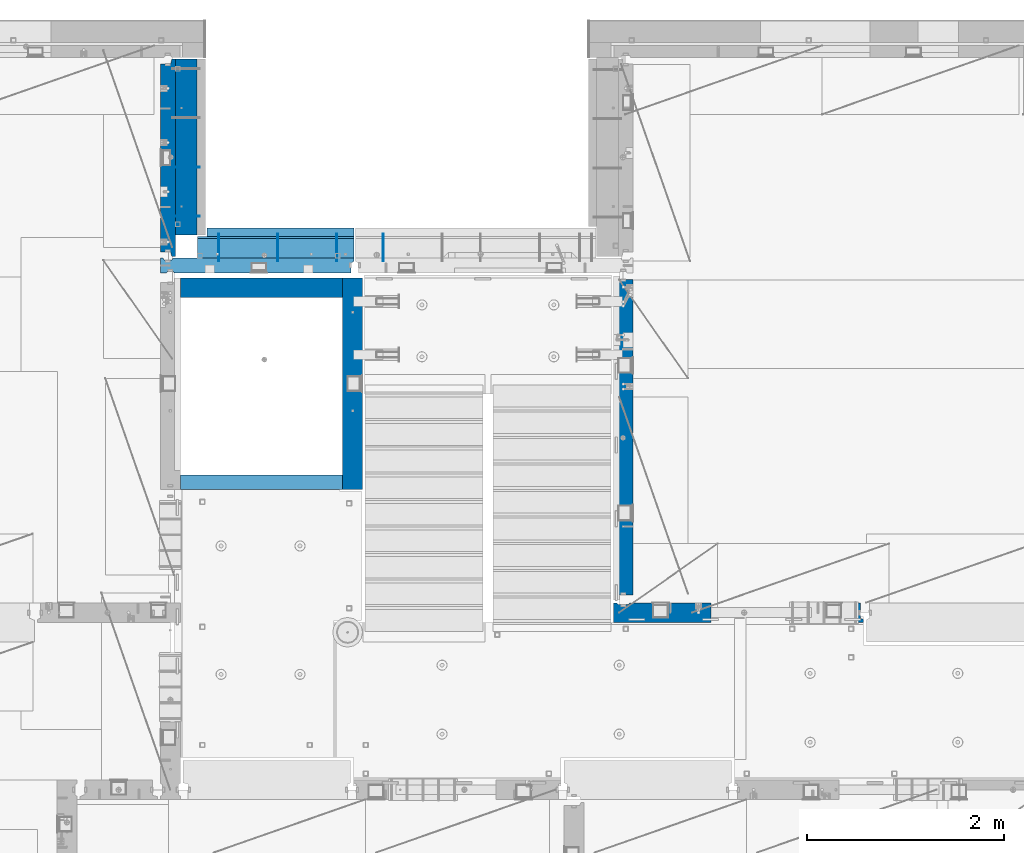
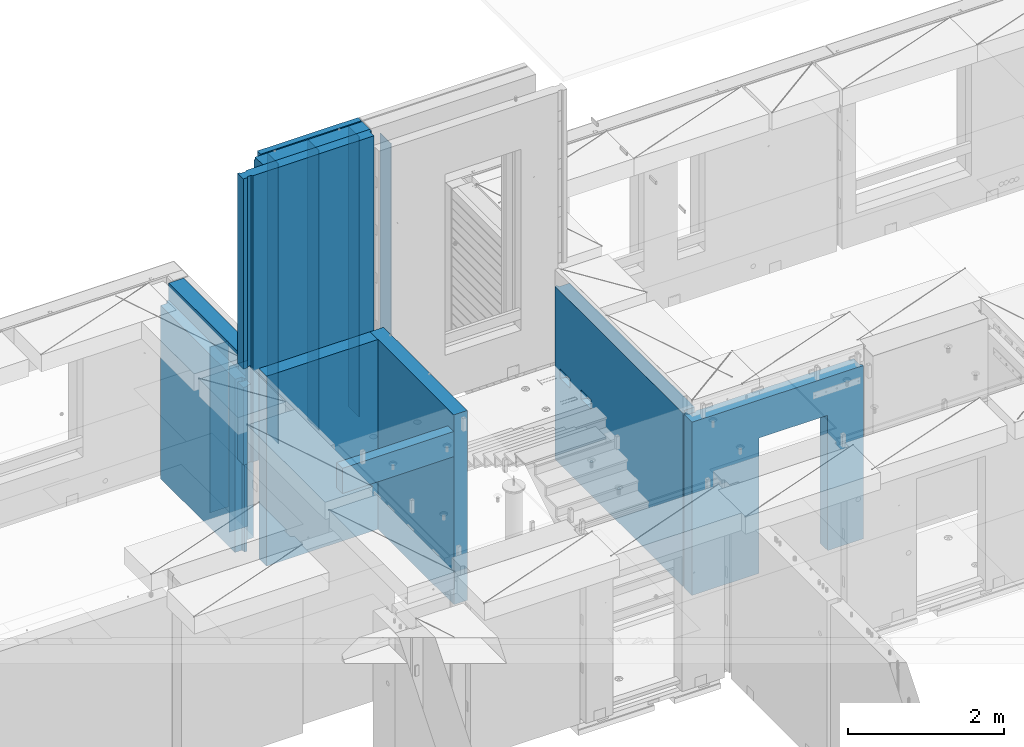
# One storey, part 238 of 352: 16 walls, 7 elements without a shape of their own.
"""IFC2X3 building model written with IfcOpenShell, lengths in millimetres."""

from ifc_helpers import new_model, si_unit, frame, origin_with_axes, place, context, subcontext, project, spatial, faceted_brep, material, type_object, element, aggregate, save


model = new_model("IFC2X3")

# Units and contexts
model_context = context("Model", 3, precision=1e-05, world=origin_with_axes())
body_context = subcontext(model_context, "Body", "Model", "MODEL_VIEW")
ifc_project = project(units=[si_unit("LENGTHUNIT", "METRE", prefix="MILLI"), si_unit("AREAUNIT", "SQUARE_METRE"), si_unit("VOLUMEUNIT", "CUBIC_METRE"), si_unit("MASSUNIT", "GRAM", prefix="KILO"), si_unit("TIMEUNIT", "SECOND"), si_unit("PLANEANGLEUNIT", "RADIAN"), si_unit("SOLIDANGLEUNIT", "STERADIAN"), si_unit("THERMODYNAMICTEMPERATUREUNIT", "DEGREE_CELSIUS"), si_unit("LUMINOUSINTENSITYUNIT", "LUMEN")], contexts=[model_context])

# Site, building, storey
site_placement = place(None, origin_with_axes())
site = spatial("IfcSite", under=ifc_project, at=site_placement, CompositionType="ELEMENT")
building_placement = place(site_placement, origin_with_axes())
building = spatial("IfcBuilding", under=site, at=building_placement, CompositionType="ELEMENT")
storey_placement = place(building_placement, origin_with_axes())
storey = spatial("IfcBuildingStorey", under=building, at=storey_placement, Name="6", CompositionType="ELEMENT", Elevation=0.0)

# Assembly, walls
assembly_1_placement = place(storey_placement, origin_with_axes())
assembly_1 = element("IfcElementAssembly", 1, at=assembly_1_placement, inside=storey, AssemblyPlace="NOTDEFINED", PredefinedType="REINFORCEMENT_UNIT")
ifc_material_1 = material(Name="Undefined")
wall_type_1 = type_object("IfcWallType", PredefinedType="NOTDEFINED")
wall_1_placement = place(assembly_1_placement, frame((17730.0, 21005.0, 98115.0), z_axis=(0.0, 0.0, 1.0), x_axis=(1.0, 0.0, 0.0)))
wall_1 = element("IfcWall", 2, at=wall_1_placement, type_object=wall_type_1, material=ifc_material_1, Name="(PD)", context=body_context, shape_type="Brep", body=[
    faceted_brep([(0.0, 5.0, -1300.0), (0.0, 5.0, 1300.0), (280.0, 5.0, 1300.0), (280.0, 5.0, -1300.0), (0.0, -5.0, 1300.0), (280.0, -5.0, 1300.0), (0.0, -5.0, -1300.0), (280.0, -5.0, -1300.0)], [[[0, 1, 2, 3]], [[1, 4, 5, 2]], [[4, 6, 7, 5]], [[6, 0, 3, 7]], [[5, 7, 3, 2]], [[6, 4, 1, 0]]]),
])
wall_2_placement = place(assembly_1_placement, frame((17730.0, 21505.0, 98115.0), z_axis=(0.0, 0.0, 1.0), x_axis=(1.0, 0.0, 0.0)))
wall_2 = element("IfcWall", 3, at=wall_2_placement, type_object=wall_type_1, material=ifc_material_1, Name="(PD)", context=body_context, shape_type="Brep", body=[
    faceted_brep([(0.0, 5.0, -1300.0), (0.0, 5.0, 1300.0), (280.0, 5.0, 1300.0), (280.0, 5.0, -1300.0), (0.0, -5.0, 1300.0), (280.0, -5.0, 1300.0), (0.0, -5.0, -1300.0), (280.0, -5.0, -1300.0)], [[[0, 1, 2, 3]], [[1, 4, 5, 2]], [[4, 6, 7, 5]], [[6, 0, 3, 7]], [[5, 7, 3, 2]], [[6, 4, 1, 0]]]),
])

# Assembly, wall
assembly_2_placement = place(storey_placement, origin_with_axes())
assembly_2 = element("IfcElementAssembly", 4, at=assembly_2_placement, inside=storey, AssemblyPlace="NOTDEFINED", PredefinedType="REINFORCEMENT_UNIT")
wall_type_2 = type_object("IfcWallType", PredefinedType="NOTDEFINED")
wall_3_placement = place(assembly_2_placement, frame((19870.0002441406, 20550.0, 100370.0), z_axis=(0.0, 0.0, 1.0), x_axis=(0.0, 1.0, 0.0)))
wall_3 = element("IfcWall", 5, at=wall_3_placement, type_object=wall_type_2, material=ifc_material_1, Name="(PD)", context=body_context, shape_type="Brep", body=[
    faceted_brep([(0.0, 5.0, -2060.0), (0.0, 5.0, 2060.0), (280.0, 5.0, 2060.0), (280.0, 5.0, -2060.0), (0.0, -5.0, 2060.0), (280.0, -5.0, 2060.0), (0.0, -5.0, -2060.0), (280.0, -5.0, -2060.0)], [[[0, 1, 2, 3]], [[1, 4, 5, 2]], [[4, 6, 7, 5]], [[6, 0, 3, 7]], [[5, 7, 3, 2]], [[6, 4, 1, 0]]]),
])
aggregate(assembly_2, [wall_3])

assembly_3_placement = place(storey_placement, origin_with_axes())
assembly_3 = element("IfcElementAssembly", 6, at=assembly_3_placement, inside=storey, AssemblyPlace="NOTDEFINED", PredefinedType="REINFORCEMENT_UNIT")
ifc_material_2 = material(Name="CONCRETE/C25/30")
wall_type_3 = type_object("IfcWallType", PredefinedType="NOTDEFINED")
wall_4_placement = place(assembly_3_placement, frame((22310.0, 16980.0, 98112.5), z_axis=(0.0, 0.0, 1.0), x_axis=(1.0, 0.0, 0.0)))
wall_4 = element("IfcWall", 7, at=wall_4_placement, type_object=wall_type_3, material=ifc_material_2, context=body_context, shape_type="Brep", body=[
    faceted_brep([(890.000686645508, 100.0, 762.5), (890.000686645508, -100.0, 762.5), (890.000686645508, -100.0, -1357.5), (890.000686645508, 100.0, -1357.5), (1910.00068664551, 100.0, 762.5), (1910.00068664551, -100.0, 762.5), (1910.00068664551, 100.0, -1357.5), (1910.00068664551, -100.0, -1357.5), (-100.0, -100.0, -1357.5), (-100.0, -100.0, 1357.5), (-100.0, 100.0, 1357.5), (-100.0, 100.0, -1357.5), (2440.0, -100.0, 1357.5), (2440.0, -100.0, -1357.5), (2440.0, -70.0000000000036, -1357.5), (2440.0, -70.0000000000036, 1357.5), (2410.0, 100.0, 1357.5), (2410.0, -57.0, 1357.5), (2410.0, -57.0, -1357.5), (2410.0, 100.0, -1357.5), (65.0000000000036, 100.0, 1357.5), (52.0, 80.0, 1357.5), (-52.0, 80.0, 1357.5), (-65.0, 100.0, 1357.5), (-65.0, 100.0, -1357.5), (-52.0, 80.0, -1357.5), (52.0, 80.0, -1357.5), (65.0000000000036, 100.0, -1357.5)], [[[0, 1, 2, 3]], [[4, 5, 1, 0]], [[6, 7, 5, 4]], [[8, 9, 10, 11]], [[12, 13, 14, 15]], [[16, 17, 18, 19]], [[15, 14, 18, 17]], [[16, 20, 21, 22, 23, 10, 9, 12, 15, 17]], [[11, 10, 23, 24]], [[22, 25, 24, 23]], [[21, 26, 25, 22]], [[20, 27, 26, 21]], [[8, 11, 24, 25, 26, 27, 3, 2]], [[13, 12, 9, 8, 2, 1, 5, 7]], [[19, 18, 14, 13, 7, 6]], [[3, 27, 20, 16, 19, 6, 4, 0]]]),
])
aggregate(assembly_3, [wall_4])

assembly_4_placement = place(storey_placement, origin_with_axes())
assembly_4 = element("IfcElementAssembly", 8, at=assembly_4_placement, inside=storey, AssemblyPlace="NOTDEFINED", PredefinedType="REINFORCEMENT_UNIT")
wall_5_placement = place(assembly_4_placement, frame((22310.0, 16980.0, 98112.5), z_axis=(0.0, 0.0, 1.0), x_axis=(0.0, 1.0, 0.0)))
wall_5 = element("IfcWall", 9, at=wall_5_placement, type_object=wall_type_3, material=ifc_material_2, context=body_context, shape_type="Brep", body=[
    faceted_brep([(3059.9952678883, 0.0998642726626713, 102.5), (3259.9952678883, 0.0998642726626713, 102.5), (3259.9952678883, 0.0998642726626713, -7.5), (3059.9952678883, 0.0998642726626713, -7.5), (3034.9952678883, 100.099864272663, -7.5), (3284.9952678883, 100.099864272663, -7.5), (3034.9952678883, 100.099864272663, 137.5), (3284.9952678883, 100.099864272663, 137.5), (3420.0, 70.0, 1357.5), (3420.0, 100.0, 1357.5), (130.0, 100.0, 1357.5), (130.0, 70.0, 1357.5), (180.0, 57.0, 1357.5), (180.0, -100.0, 1357.5), (3384.99999178648, -100.000000948603, 1357.5), (3385.00000172571, 57.0000007519884, 1357.5), (130.0, 100.0, -1357.5), (130.0, 70.0, -1357.5), (180.0, 57.0, -1357.5), (180.0, -100.0, -1357.5), (3384.99999178648, -100.0, -1357.5), (3385.00000172571, 57.0000007519884, -1357.5), (3420.0, 100.0, -1357.5), (3420.0, 70.0, -1357.5), (2519.9952678883, 0.0998642726626713, 102.5), (2719.9952678883, 0.0998642726626713, 102.5), (2719.9952678883, 0.0998642726626713, -7.5), (2519.9952678883, 0.0998642726626713, -7.5), (2744.9952678883, 100.099864272663, -7.5), (2744.9952678883, 100.099864272663, 137.5), (2494.9952678883, 100.099864272663, -7.5), (2494.9952678883, 100.099864272663, 137.5)], [[[0, 1, 2, 3]], [[4, 3, 2, 5]], [[6, 0, 3, 4]], [[7, 1, 0, 6]], [[5, 2, 1, 7]], [[8, 9, 10, 11, 12, 13, 14, 15]], [[10, 16, 17, 11]], [[11, 17, 18, 12]], [[13, 12, 18, 19]], [[13, 19, 20, 14]], [[14, 20, 21, 15]], [[19, 18, 17, 16, 22, 23, 21, 20]], [[15, 21, 23, 8]], [[22, 9, 8, 23]], [[24, 25, 26, 27]], [[28, 26, 25, 29]], [[30, 27, 26, 28]], [[31, 24, 27, 30]], [[29, 25, 24, 31]], [[16, 10, 9, 22], [4, 5, 7, 6], [30, 28, 29, 31]]]),
])
aggregate(assembly_4, [wall_5])

# Wall
ifc_material_3 = material(Name="COS5gt")
wall_type_4 = type_object("IfcWallType", PredefinedType="NOTDEFINED")
wall_6_placement = place(assembly_1_placement, frame((17870.0, 22605.0, 98247.5), z_axis=(0.0, 0.0, 1.0), x_axis=(0.0, -1.0, 0.0)))
wall_6 = element("IfcWall", 10, at=wall_6_placement, type_object=wall_type_4, material=ifc_material_3, context=body_context, shape_type="Brep", body=[
    faceted_brep([(0.0, 110.0, -1492.5), (0.0, 110.0, 1492.5), (1790.0, 110.0, 1492.5), (1790.0, 110.0, -1492.5), (0.0, -110.0, 1492.5), (1790.0, -110.0, 1492.5), (0.0, -110.0, -1492.5), (1790.0, -110.0, -1492.5)], [[[0, 1, 2, 3]], [[1, 4, 5, 2]], [[4, 6, 7, 5]], [[6, 0, 3, 7]], [[5, 7, 3, 2]], [[6, 4, 1, 0]]]),
])

wall_type_5 = type_object("IfcWallType", PredefinedType="NOTDEFINED")
wall_7_placement = place(assembly_1_placement, frame((17685.0, 22605.0, 98112.5), z_axis=(0.0, 0.0, 1.0), x_axis=(0.0, -1.0, 0.0)))
wall_7 = element("IfcWall", 11, at=wall_7_placement, type_object=wall_type_5, material=ifc_material_2, context=body_context, shape_type="Brep", body=[
    faceted_brep([(1959.99999772087, -75.0, 1357.5), (1959.99999772087, -75.0, -1357.5), (1959.99999772087, 27.0, -1357.5), (1959.99999772087, 27.0, 1357.5), (2009.99999772087, 40.0, -1357.5), (2009.99999772087, 40.0, 1357.5), (50.0, -75.0, 1357.5), (50.0, 27.0, 1357.5), (50.0, 27.0, -1357.5), (50.0, -75.0, -1357.5), (0.0, 40.0, 1357.5), (0.0, 40.0, -1357.5), (0.0, 75.0, 1357.5), (0.0, 75.0, -1357.5), (2009.99999772087, 75.0, 1357.5), (2009.99999772087, 75.0, -1357.5)], [[[0, 1, 2, 3]], [[3, 2, 4, 5]], [[6, 7, 8, 9]], [[10, 11, 8, 7]], [[12, 13, 11, 10]], [[13, 12, 14, 15]], [[15, 14, 5, 4]], [[11, 13, 15, 4, 2, 1, 9, 8]], [[1, 0, 6, 9]], [[0, 3, 5, 14, 12, 10, 7, 6]]]),
])

aggregate(assembly_1, [wall_6, wall_1, wall_2, wall_7])

# Assembly, walls
assembly_5_placement = place(storey_placement, origin_with_axes())
assembly_5 = element("IfcElementAssembly", 12, at=assembly_5_placement, inside=storey, AssemblyPlace="NOTDEFINED", PredefinedType="REINFORCEMENT_UNIT")
wall_type_6 = type_object("IfcWallType", PredefinedType="NOTDEFINED")
wall_8_placement = place(assembly_5_placement, frame((17809.9999105288, 20280.0000293051, 98242.5), z_axis=(0.0, 0.0, 1.0), x_axis=(1.0, 0.0, 0.0)))
wall_8 = element("IfcWall", 13, at=wall_8_placement, type_object=wall_type_6, material=ifc_material_2, context=body_context, shape_type="Brep", body=[
    faceted_brep([(0.0, 100.0, -1487.5), (0.0, 100.0, 1487.5), (1649.99977111816, 100.0, 1487.5), (1649.99977111816, 100.0, -1487.5), (0.0, -100.0, 1487.5), (1649.99977111816, -100.0, 1487.5), (0.0, -100.0, -1487.5), (1649.99977111816, -100.0, -1487.5)], [[[0, 1, 2, 3]], [[1, 4, 5, 2]], [[4, 6, 7, 5]], [[6, 0, 3, 7]], [[5, 7, 3, 2]], [[6, 4, 1, 0]]]),
])
wall_9_placement = place(assembly_5_placement, frame((19559.999681647, 18229.9992663657, 98242.5), z_axis=(0.0, 0.0, 1.0), x_axis=(0.0, 1.0, 0.0)))
wall_9 = element("IfcWall", 14, at=wall_9_placement, type_object=wall_type_6, material=ifc_material_2, context=body_context, shape_type="Brep", body=[
    faceted_brep([(1470.00546574604, -0.100182625668822, -27.5), (1270.00546574604, -0.100182625668822, -27.5), (1270.00546574604, -0.100182625668822, -137.5), (1470.00546574604, -0.100182625668822, -137.5), (1245.00546574604, -100.100182625669, -137.5), (1245.00546574604, -100.100182625669, 7.5), (1495.00546574604, -100.100182625669, -137.5), (1495.00546574604, -100.100182625669, 7.5), (0.0, -100.0, -1487.5), (0.0, 100.0, -1487.5), (2150.00073363433, 100.0, -1487.5), (2150.00073363433, -100.0, -1487.5), (0.0, -100.0, 1487.5), (0.0, 100.0, 1487.5), (2150.00073363433, -100.0, 1487.5), (2150.00073363433, 100.0, 1487.5), (2010.00546574604, -0.100182625668822, -27.5), (1810.00546574604, -0.100182625668822, -27.5), (1810.00546574604, -0.100182625668822, -137.5), (2010.00546574604, -0.100182625668822, -137.5), (1785.00546574604, -100.100182625669, 7.5), (2035.00546574604, -100.100182625669, 7.5), (1785.00546574604, -100.100182625669, -137.5), (2035.00546574604, -100.100182625669, -137.5)], [[[0, 1, 2, 3]], [[4, 2, 1, 5]], [[6, 3, 2, 4]], [[7, 0, 3, 6]], [[5, 1, 0, 7]], [[8, 9, 10, 11]], [[8, 12, 13, 9]], [[13, 12, 14, 15]], [[9, 13, 15, 10]], [[14, 11, 10, 15]], [[16, 17, 18, 19]], [[20, 17, 16, 21]], [[22, 18, 17, 20]], [[23, 19, 18, 22]], [[21, 16, 19, 23]], [[12, 8, 11, 14], [4, 5, 7, 6], [22, 20, 21, 23]]]),
])
wall_type_7 = type_object("IfcWallType", PredefinedType="NOTDEFINED")
wall_10_placement = place(assembly_5_placement, frame((17809.9999105288, 18304.9992663657, 99272.5), z_axis=(0.0, 0.0, 1.0), x_axis=(1.0, 0.0, 0.0)))
wall_10 = element("IfcWall", 15, at=wall_10_placement, type_object=wall_type_7, material=ifc_material_2, context=body_context, shape_type="Brep", body=[
    faceted_brep([(0.0, 75.0, -197.5), (0.0, 75.0, 197.5), (1649.99961853027, 75.0, 197.5), (1649.99961853027, 75.0, -197.5), (0.0, -75.0, 197.5), (1649.99961853027, -75.0, 197.5), (0.0, -75.0, -197.5), (1649.99961853027, -75.0, -197.5)], [[[0, 1, 2, 3]], [[1, 4, 5, 2]], [[4, 6, 7, 5]], [[6, 0, 3, 7]], [[5, 7, 3, 2]], [[6, 4, 1, 0]]]),
])
aggregate(assembly_5, [wall_8, wall_10, wall_9])

# Assemblies, walls
assembly_6_placement = place(storey_placement, origin_with_axes())
assembly_6 = element("IfcElementAssembly", 16, at=assembly_6_placement, inside=storey, AssemblyPlace="NOTDEFINED", PredefinedType="REINFORCEMENT_UNIT")
ifc_material_4 = material(Name="CONCRETE/C30/37")
wall_type_8 = type_object("IfcWallType", PredefinedType="NOTDEFINED")
wall_11_placement = place(assembly_6_placement, frame((18080.0, 20842.5, 100497.5), z_axis=(0.0, 0.0, 1.0), x_axis=(1.0, 0.0, 0.0)))
wall_11 = element("IfcWall", 17, at=wall_11_placement, type_object=wall_type_8, material=ifc_material_4, context=body_context, shape_type="Brep", body=[
    faceted_brep([(1495.0, 42.4999996032857, 2092.99999994476), (0.0, 42.5, 2092.99999994476), (3.63797880709171e-12, 32.4999992499361, 2094.99999999923), (1495.0, 32.4999992499361, 2094.99999999921), (3.63797880709171e-12, 32.4999991119403, 2105.00000040044), (1495.0, 32.4999991119294, 2105.00000040043), (1495.0, 42.4999992423946, 2106.99999988925), (0.0, 42.5, 2106.99999988925), (1495.0, 42.4999992423946, 1956.99999988925), (1495.0, 32.4999991119294, 1955.00000040043), (0.0, 32.4999991119403, 1955.00000040044), (0.0, 42.5, 1956.99999988925), (1495.0, 32.4999992499361, 1944.99999999921), (0.0, 32.4999992499361, 1944.99999999923), (1495.0, 42.4999994789832, 1942.99999994476), (0.0, 42.5, 1942.99999994476), (1495.0, 42.4999992423946, 1806.99999988925), (0.0, 42.5, 1806.99999988925), (1495.0, 32.4999991119294, 1805.00000040043), (0.0, 32.4999991119403, 1805.00000040044), (1495.0, 32.4999992499361, 1794.99999999921), (0.0, 32.4999992499361, 1794.99999999923), (1495.0, 42.4999994183709, 1792.99999994476), (0.0, 42.5, 1792.99999994476), (1495.0, 42.4999992423946, 1656.99999988925), (0.0, 42.5, 1656.99999988925), (1495.0, 32.4999991119294, 1655.00000040043), (0.0, 32.4999991119403, 1655.00000040044), (1495.0, 32.4999992499361, 1644.99999999921), (0.0, 32.4999992499361, 1644.99999999923), (1495.0, 42.4999993824822, 1642.99999994476), (0.0, 42.5, 1642.99999994476), (1495.0, 42.4999992423946, 1506.99999988925), (0.0, 42.5, 1506.99999988925), (1495.0, 32.4999991119294, 1505.00000040043), (0.0, 32.4999991119403, 1505.00000040044), (1495.0, 32.4999992499361, 1494.99999999921), (0.0, 32.4999992499361, 1494.99999999923), (1495.0, 42.4999993587517, 1492.99999994476), (0.0, 42.5, 1492.99999994476), (1495.0, 42.4999992423946, 1356.99999988925), (0.0, 42.5, 1356.99999988925), (1495.0, 32.4999991119294, 1355.00000040043), (-3.63797880709171e-12, 32.4999991127006, 1355.00000040044), (1495.0, 32.4999992499361, 1344.99999999921), (-3.63797880709171e-12, 32.4999992507037, 1344.99999999926), (1495.0, 42.4999993418969, 1342.99999994476), (0.0, 42.5, 1342.99999994476), (1495.0, 42.4999992423946, 1206.99999988925), (0.0, 42.5, 1206.99999988925), (1495.0, 32.4999991119294, 1205.00000040043), (0.0, 32.4999991127006, 1205.00000040044), (1495.0, 32.4999992499361, 1194.99999999921), (0.0, 32.4999992507037, 1194.99999999926), (1495.0, 42.4999993293059, 1192.99999994476), (0.0, 42.5, 1192.99999994476), (1495.0, 42.4999992423946, 1056.99999988925), (0.0, 42.5, 1056.99999988925), (1495.0, 32.4999991119294, 1055.00000040043), (0.0, 32.4999991127006, 1055.00000040044), (1495.0, 32.4999992499361, 1044.99999999921), (0.0, 32.4999992507037, 1044.99999999926), (1495.0, 42.4999993195452, 1042.99999994476), (0.0, 42.5, 1042.99999994476), (1495.0, 42.4999992423946, 906.999999889245), (0.0, 42.5, 906.999999889245), (1495.0, 32.4999991119294, 905.000000400425), (0.0, 32.4999991127006, 905.00000040044), (1495.0, 32.4999992499361, 894.999999999214), (0.0, 32.4999992507037, 894.999999999258), (1495.0, 42.4999993117563, 892.999999944761), (0.0, 42.5, 892.999999944761), (1495.0, 42.4999992423946, 756.999999889245), (0.0, 42.5, 756.999999889245), (1495.0, 32.4999991119294, 755.000000400425), (0.0, 32.4999991127006, 755.00000040044), (1495.0, 32.4999992499361, 744.999999999214), (0.0, 32.4999992507037, 744.999999999258), (1495.0, 42.4999993053934, 742.999999944761), (0.0, 42.5, 742.999999944761), (1495.0, 42.4999992423946, 606.999999889245), (0.0, 42.5, 606.999999889245), (1495.0, 32.4999991119294, 605.000000400425), (3.63797880709171e-12, 32.4999991127006, 605.00000040044), (1495.0, 32.4999992499361, 594.999999999214), (3.63797880709171e-12, 32.4999992507037, 594.999999999258), (1495.0, 42.4999993001184, 592.999999944761), (0.0, 42.5, 592.999999944761), (1495.0, 42.4999992424127, 456.99999988926), (0.0, 42.5, 456.999999889245), (1495.0, 32.4999991119439, 455.00000040044), (0.0, 32.4999991127006, 455.00000040044), (1495.0, 32.4999992499506, 444.999999999229), (0.0, 32.4999992507037, 444.999999999258), (1495.0, 42.4999992956582, 442.999999944775), (0.0, 42.5, 442.999999944761), (1495.0, 42.4999992424273, 306.999999889245), (0.0, 42.5, 306.999999889245), (1495.0, 32.4999991119585, 305.000000400425), (-3.63797880709171e-12, 32.4999991127006, 305.00000040044), (1495.0, 32.4999992499688, 294.999999999229), (-3.63797880709171e-12, 32.4999992507037, 294.999999999258), (1495.0, 42.4999992918456, 292.999999944761), (0.0, 42.5, 292.999999944761), (1495.0, 42.4999992424455, 156.999999889245), (0.0, 42.5, 156.999999889245), (1495.0, 32.4999991119766, 155.00000040044), (-3.63797880709171e-12, 32.4999991127006, 155.00000040044), (1495.0, 32.4999992499761, 144.999999999243), (-3.63797880709171e-12, 32.4999992507037, 144.999999999258), (1495.0, 42.4999992885423, 142.999999944761), (0.0, 42.5, 142.999999944761), (1495.0, 42.4999992424564, 6.99999988923082), (0.0, 42.5, 6.99999988924537), (1495.0, 32.4999991119876, 5.0000004004105), (0.0, 32.4999991127006, 5.0000004004396), (1495.0, 32.499999249987, -5.00000000077125), (0.0, 32.4999992507037, -5.00000000074215), (1495.0, 42.4999992856538, -7.00000005525362), (0.0, 42.5, -7.00000005523907), (1495.0, 42.4999992424673, -143.000000110769), (0.0, 42.5, -143.000000110755), (1495.0, 32.4999991119985, -144.99999959959), (3.63797880709171e-12, 32.4999991127006, -144.99999959956), (1495.0, 32.4999992500016, -155.000000000786), (3.63797880709171e-12, 32.4999992507037, -155.000000000742), (1495.0, 42.4999992831108, -157.000000055254), (0.0, 42.5, -157.000000055239), (1495.0, 42.4999992424782, -293.00000011074), (0.0, 42.5, -293.000000110755), (1495.0, 32.499999112013, -294.99999959956), (0.0, 32.4999991127006, -294.99999959956), (1495.0, 32.4999992500198, -305.000000000771), (0.0, 32.4999992507037, -305.000000000742), (1495.0, 42.4999992808698, -307.000000055225), (0.0, 42.5, -307.000000055239), (1495.0, 42.4999992425073, -443.000000110755), (0.0, 42.5, -443.000000110755), (1495.0, 32.4999991120385, -444.99999959956), (0.0, 32.4999991127006, -444.99999959956), (1495.0, 32.4999992500343, -455.000000000771), (0.0, 32.4999992507037, -455.000000000742), (1495.0, 42.4999992788507, -457.000000055239), (0.0, 42.5, -457.000000055239), (1495.0, 42.4999992425182, -593.000000110755), (0.0, 42.5, -593.000000110755), (1495.0, 32.4999991120458, -594.99999959956), (3.63797880709171e-12, 32.4999991127006, -594.99999959956), (1495.0, 32.4999992500452, -605.000000000771), (3.63797880709171e-12, 32.4999992507037, -605.000000000742), (1495.0, 42.4999992770245, -607.000000055239), (0.0, 42.5, -607.000000055239), (1495.0, 42.4999992425182, -743.000000110755), (0.0, 42.5, -743.000000110755), (1495.0, 32.4999991120494, -744.999999599575), (0.0, 32.4999991127006, -744.99999959956), (1495.0, 32.4999992500525, -755.000000000771), (0.0, 32.4999992507037, -755.000000000742), (1495.0, 42.4999992795674, -757.000000055239), (0.0, 42.5, -757.000000055239), (1495.0, 42.499999246902, -893.000000110784), (0.0, 42.5, -893.000000110755), (1495.0, 32.4999991164295, -894.99999959959), (0.0, 32.4999991127006, -894.99999959956), (1495.0, 32.4999992544326, -905.000000000771), (0.0, 32.4999992507037, -905.000000000742), (1495.0, 42.4999992775483, -907.000000055268), (0.0, 42.5, -907.000000055239), (1495.0, 42.4999992463527, -1043.00000011075), (0.0, 42.5, -1043.00000011075), (1495.0, 32.4999991158838, -1044.99999959957), (0.0, 32.4999991127006, -1044.99999959956), (1495.0, 32.4999992538942, -1055.00000000077), (0.0, 32.4999992507037, -1055.00000000074), (1495.0, 42.4999992756748, -1057.00000005524), (0.0, 42.5, -1057.00000005524), (1495.0, 42.4999992458179, -1193.00000011075), (0.0, 42.5, -1193.00000011075), (1495.0, 32.4999991153491, -1194.99999959957), (0.0, 32.4999991127006, -1194.99999959956), (1495.0, 32.4999992533594, -1205.00000000079), (0.0, 32.4999992507037, -1205.00000000074), (1495.0, 42.4999992739249, -1207.00000005524), (0.0, 42.5, -1207.00000005524), (1495.0, 42.4999992452977, -1343.00000011074), (0.0, 42.5, -1343.00000011075), (1495.0, 32.4999991148325, -1344.99999959956), (0.0, 32.4999991127006, -1344.99999959956), (1495.0, 32.4999992528392, -1355.00000000077), (0.0, 32.4999992507037, -1355.00000000074), (1495.0, 42.499999272266, -1357.00000005522), (0.0, 42.5, -1357.00000005524), (1495.0, 42.4999992447702, -1493.00000011075), (0.0, 42.5, -1493.00000011075), (1495.0, 32.4999991143013, -1494.99999959957), (3.63797880709171e-12, 32.499999114305, -1494.99999959956), (1495.0, 32.4999992523044, -1505.00000000077), (3.63797880709171e-12, 32.4999992523044, -1505.00000000077), (1495.0, 42.4999992706944, -1507.00000005524), (0.0, 42.5, -1507.00000005524), (1495.0, 42.4999992442426, -1643.00000011074), (0.0, 42.5, -1643.00000011074), (1495.0, 32.4999991137702, -1644.99999959955), (0.0, 32.4999991137702, -1644.99999959955), (1495.0, 32.4999992517696, -1655.00000000074), (0.0, 32.4999992517696, -1655.00000000074), (1495.0, 42.4999992691955, -1657.00000005522), (0.0, 42.5, -1657.00000005522), (1495.0, 42.4999992437079, -1793.00000011077), (0.0, 42.5, -1793.00000011077), (1495.0, 32.499999113239, -1794.99999959957), (0.0, 32.499999113239, -1794.99999959957), (1495.0, 32.4999992512385, -1805.00000000077), (0.0, 32.4999992512385, -1805.00000000077), (1495.0, 42.4999992677476, -1807.00000005525), (0.0, 42.5, -1807.00000005525), (1495.0, 42.4999992431549, -1943.00000011074), (0.0, 42.5, -1943.00000011074), (1495.0, 32.4999991126861, -1944.99999959956), (0.0, 32.4999991126861, -1944.99999959956), (1495.0, 32.4999992506928, -1955.00000000077), (0.0, 32.4999992506928, -1955.00000000077), (1495.0, 42.4999992663834, -1957.00000005522), (0.0, 42.5, -1957.00000005522), (1495.0, 42.4999992426237, -2093.00000011075), (0.0, 42.5, -2093.00000011075), (1495.0, 32.4999991121585, -2094.99999959957), (0.0, 32.4999991121585, -2094.99999959957), (1495.0, 32.4999992501653, -2105.00000000079), (0.0, 32.4999992501653, -2105.00000000079), (1495.0, 42.5, -2107.00000005524), (0.0, 42.5, -2107.00000005524), (1495.0, 42.5, -2242.5), (0.0, 42.5, -2242.5), (0.0, -42.5, -2242.5), (1495.0, -42.5, -2242.5), (0.0, -42.5, 2242.5), (1495.0, -42.5, 2242.5), (0.0, 42.5, 2242.5), (1495.0, 42.5, 2242.5)], [[[0, 1, 2, 3]], [[3, 2, 4, 5]], [[6, 5, 4, 7]], [[8, 9, 10, 11]], [[12, 13, 10, 9]], [[14, 15, 13, 12]], [[16, 17, 15, 14]], [[16, 18, 19, 17]], [[20, 21, 19, 18]], [[22, 23, 21, 20]], [[24, 25, 23, 22]], [[24, 26, 27, 25]], [[28, 29, 27, 26]], [[30, 31, 29, 28]], [[32, 33, 31, 30]], [[32, 34, 35, 33]], [[36, 37, 35, 34]], [[38, 39, 37, 36]], [[40, 41, 39, 38]], [[40, 42, 43, 41]], [[44, 45, 43, 42]], [[46, 47, 45, 44]], [[48, 49, 47, 46]], [[48, 50, 51, 49]], [[52, 53, 51, 50]], [[54, 55, 53, 52]], [[56, 57, 55, 54]], [[56, 58, 59, 57]], [[60, 61, 59, 58]], [[62, 63, 61, 60]], [[64, 65, 63, 62]], [[64, 66, 67, 65]], [[68, 69, 67, 66]], [[70, 71, 69, 68]], [[72, 73, 71, 70]], [[72, 74, 75, 73]], [[76, 77, 75, 74]], [[78, 79, 77, 76]], [[80, 81, 79, 78]], [[80, 82, 83, 81]], [[84, 85, 83, 82]], [[86, 87, 85, 84]], [[88, 89, 87, 86]], [[88, 90, 91, 89]], [[92, 93, 91, 90]], [[94, 95, 93, 92]], [[96, 97, 95, 94]], [[96, 98, 99, 97]], [[100, 101, 99, 98]], [[102, 103, 101, 100]], [[104, 105, 103, 102]], [[104, 106, 107, 105]], [[108, 109, 107, 106]], [[110, 111, 109, 108]], [[112, 113, 111, 110]], [[112, 114, 115, 113]], [[116, 117, 115, 114]], [[118, 119, 117, 116]], [[120, 121, 119, 118]], [[120, 122, 123, 121]], [[124, 125, 123, 122]], [[126, 127, 125, 124]], [[128, 129, 127, 126]], [[128, 130, 131, 129]], [[132, 133, 131, 130]], [[134, 135, 133, 132]], [[136, 137, 135, 134]], [[136, 138, 139, 137]], [[140, 141, 139, 138]], [[142, 143, 141, 140]], [[144, 145, 143, 142]], [[144, 146, 147, 145]], [[148, 149, 147, 146]], [[150, 151, 149, 148]], [[152, 153, 151, 150]], [[152, 154, 155, 153]], [[156, 157, 155, 154]], [[158, 159, 157, 156]], [[160, 161, 159, 158]], [[160, 162, 163, 161]], [[164, 165, 163, 162]], [[166, 167, 165, 164]], [[168, 169, 167, 166]], [[168, 170, 171, 169]], [[172, 173, 171, 170]], [[174, 175, 173, 172]], [[176, 177, 175, 174]], [[176, 178, 179, 177]], [[180, 181, 179, 178]], [[182, 183, 181, 180]], [[184, 185, 183, 182]], [[184, 186, 187, 185]], [[188, 189, 187, 186]], [[190, 191, 189, 188]], [[192, 193, 191, 190]], [[192, 194, 195, 193]], [[196, 197, 195, 194]], [[198, 199, 197, 196]], [[200, 201, 199, 198]], [[200, 202, 203, 201]], [[204, 205, 203, 202]], [[206, 207, 205, 204]], [[208, 209, 207, 206]], [[208, 210, 211, 209]], [[212, 213, 211, 210]], [[214, 215, 213, 212]], [[216, 217, 215, 214]], [[216, 218, 219, 217]], [[220, 221, 219, 218]], [[222, 223, 221, 220]], [[224, 225, 223, 222]], [[224, 226, 227, 225]], [[228, 229, 227, 226]], [[230, 231, 229, 228]], [[232, 233, 231, 230]], [[234, 233, 232, 235]], [[236, 234, 235, 237]], [[238, 236, 237, 239]], [[238, 239, 6, 7]], [[2, 1, 11, 10, 13, 15, 17, 19, 21, 23, 25, 27, 29, 31, 33, 35, 37, 39, 41, 43, 45, 47, 49, 51, 53, 55, 57, 59, 61, 63, 65, 67, 69, 71, 73, 75, 77, 79, 81, 83, 85, 87, 89, 91, 93, 95, 97, 99, 101, 103, 105, 107, 109, 111, 113, 115, 117, 119, 121, 123, 125, 127, 129, 131, 133, 135, 137, 139, 141, 143, 145, 147, 149, 151, 153, 155, 157, 159, 161, 163, 165, 167, 169, 171, 173, 175, 177, 179, 181, 183, 185, 187, 189, 191, 193, 195, 197, 199, 201, 203, 205, 207, 209, 211, 213, 215, 217, 219, 221, 223, 225, 227, 229, 231, 233, 234, 236, 238, 7, 4]], [[8, 11, 1, 0]], [[239, 237, 235, 232, 230, 228, 226, 224, 222, 220, 218, 216, 214, 212, 210, 208, 206, 204, 202, 200, 198, 196, 194, 192, 190, 188, 186, 184, 182, 180, 178, 176, 174, 172, 170, 168, 166, 164, 162, 160, 158, 156, 154, 152, 150, 148, 146, 144, 142, 140, 138, 136, 134, 132, 130, 128, 126, 124, 122, 120, 118, 116, 114, 112, 110, 108, 106, 104, 102, 100, 98, 96, 94, 92, 90, 88, 86, 84, 82, 80, 78, 76, 74, 72, 70, 68, 66, 64, 62, 60, 58, 56, 54, 52, 50, 48, 46, 44, 42, 40, 38, 36, 34, 32, 30, 28, 26, 24, 22, 20, 18, 16, 14, 12, 9, 8, 0, 3, 5, 6]]]),
])
assembly_7_placement = place(assembly_6_placement, origin_with_axes())
assembly_7 = element("IfcElementAssembly", 18, at=assembly_7_placement, Name="Steel Assembly", AssemblyPlace="NOTDEFINED", PredefinedType="NOTDEFINED")
wall_type_9 = type_object("IfcWallType", PredefinedType="NOTDEFINED")
wall_12_placement = place(assembly_7_placement, frame((17985.0, 20690.0, 100497.5), z_axis=(0.0, 0.0, 1.0), x_axis=(1.0, 0.0, 0.0)))
wall_12 = element("IfcWall", 19, at=wall_12_placement, type_object=wall_type_9, material=ifc_material_3, context=body_context, shape_type="Brep", body=[
    faceted_brep([(1590.0, 90.0, 2242.5), (1590.0, 90.0, 2192.5), (0.0, 90.0, 2192.5), (0.0, 90.0, 2242.5), (1590.0, 110.0, 2192.5), (0.0, 110.0, 2192.5), (0.0, -110.0, 2242.5), (0.0, -110.0, -2242.5), (1590.0, -110.0, -2242.5), (1590.0, -110.0, 2242.5), (0.0, 90.0, -2242.5), (1590.0, 90.0, -2242.5), (0.0, 90.0, -2192.5), (1590.0, 90.0, -2192.5), (1590.0, 110.0, -2192.5), (0.0, 110.0, -2192.5)], [[[0, 1, 2, 3]], [[4, 5, 2, 1]], [[6, 7, 8, 9]], [[8, 7, 10, 11]], [[11, 10, 12, 13]], [[14, 13, 12, 15]], [[0, 9, 8, 11, 13, 14, 4, 1]], [[6, 9, 0, 3]], [[15, 12, 10, 7, 6, 3, 2, 5]], [[14, 15, 5, 4]]]),
])
aggregate(assembly_7, [wall_12])
wall_type_10 = type_object("IfcWallType", PredefinedType="NOTDEFINED")
wall_13_placement = place(assembly_6_placement, frame((18200.0002441406, 20550.0, 100505.0), z_axis=(0.0, 0.0, 1.0), x_axis=(0.0, 1.0, 0.0)))
wall_13 = element("IfcWall", 20, at=wall_13_placement, type_object=wall_type_10, material=ifc_material_1, Name="(PD)", context=body_context, shape_type="Brep", body=[
    faceted_brep([(0.0, 5.0, -2195.0), (0.0, 5.0, 2195.0), (280.0, 5.0, 2195.0), (280.0, 5.0, -2195.0), (0.0, -5.0, 2195.0), (280.0, -5.0, 2195.0), (0.0, -5.0, -2195.0), (280.0, -5.0, -2195.0)], [[[0, 1, 2, 3]], [[1, 4, 5, 2]], [[4, 6, 7, 5]], [[6, 0, 3, 7]], [[5, 7, 3, 2]], [[6, 4, 1, 0]]]),
])
wall_14_placement = place(assembly_6_placement, frame((18800.0002441406, 20550.0, 100505.0), z_axis=(0.0, 0.0, 1.0), x_axis=(0.0, 1.0, 0.0)))
wall_14 = element("IfcWall", 21, at=wall_14_placement, type_object=wall_type_10, material=ifc_material_1, Name="(PD)", context=body_context, shape_type="Brep", body=[
    faceted_brep([(0.0, 5.0, -2195.0), (0.0, 5.0, 2195.0), (280.0, 5.0, 2195.0), (280.0, 5.0, -2195.0), (0.0, -5.0, 2195.0), (280.0, -5.0, 2195.0), (0.0, -5.0, -2195.0), (280.0, -5.0, -2195.0)], [[[0, 1, 2, 3]], [[1, 4, 5, 2]], [[4, 6, 7, 5]], [[6, 0, 3, 7]], [[5, 7, 3, 2]], [[6, 4, 1, 0]]]),
])
wall_15_placement = place(assembly_6_placement, frame((19400.0002441406, 20550.0, 100505.0), z_axis=(0.0, 0.0, 1.0), x_axis=(0.0, 1.0, 0.0)))
wall_15 = element("IfcWall", 22, at=wall_15_placement, type_object=wall_type_10, material=ifc_material_1, Name="(PD)", context=body_context, shape_type="Brep", body=[
    faceted_brep([(0.0, 5.0, -2195.0), (0.0, 5.0, 2195.0), (280.0, 5.0, 2195.0), (280.0, 5.0, -2195.0), (0.0, -5.0, 2195.0), (280.0, -5.0, 2195.0), (0.0, -5.0, -2195.0), (280.0, -5.0, -2195.0)], [[[0, 1, 2, 3]], [[1, 4, 5, 2]], [[4, 6, 7, 5]], [[6, 0, 3, 7]], [[5, 7, 3, 2]], [[6, 4, 1, 0]]]),
])
wall_type_11 = type_object("IfcWallType", PredefinedType="NOTDEFINED")
wall_16_placement = place(assembly_6_placement, frame((17610.0, 20505.0, 100497.5), z_axis=(0.0, 0.0, 1.0), x_axis=(1.0, 0.0, 0.0)))
wall_16 = element("IfcWall", 23, at=wall_16_placement, type_object=wall_type_11, material=ifc_material_2, context=body_context, shape_type="Brep", body=[
    faceted_brep([(115.000001117096, 55.0000001731059, -1027.50000000003), (34.9999999425163, 55.0000001373228, -1027.50000000003), (25.0, 75.0, -1027.50000000003), (0.0, 75.0, -1027.50000000003), (0.0, -75.0, -1027.5), (59.9999958419066, -74.9999999588254, -1027.5), (72.9999999685497, -54.9999999109423, -1027.50000000001), (125.000000000018, -54.9999987882657, -1027.5), (124.999999335741, 75.0000000121363, -1027.50000000003), (125.000000000018, 74.9999999999709, -737.5), (125.000000000018, -54.9999987882657, -737.5), (72.9999999685497, -54.9999999109423, -737.5), (59.9999958419066, -74.9999999489955, -737.5), (0.0, -75.0, -737.5), (0.0, 75.0, -737.5), (25.0, 75.0, -737.5), (34.9999999425163, 55.0000001373228, -737.5), (115.000001117096, 55.0000001731059, -737.5), (1934.99999894903, -75.0000000690925, 2242.5), (1934.99999894903, -75.0, -2242.5), (1935.00000106505, 25.0000007100352, -2242.5), (1935.00000106505, 25.0000007100352, 2242.5), (140.000004863494, -75.0000042032152, 2242.5), (140.000002784363, -75.0000022790009, 2235.0), (140.000002784363, -75.0, -2242.5), (59.9999958420703, -75.0, 2242.5), (59.9999958419066, -74.9999998482599, 2235.0), (72.9999999685497, -54.9999999109423, 2235.0), (73.0000002099077, -54.9999995358958, 2242.5), (126.9999998731, -54.9999987450828, 2235.0), (127.000000034488, -55.0000005645015, 2242.5), (126.9999998731, -54.9999987450828, -2242.5), (1965.0, 75.0, -2242.5), (1965.0, 75.0, 2242.5), (1965.0, 45.0, 2242.5), (1965.0, 45.0, -2242.5), (72.9999999685497, -54.9999999109423, -2242.5), (59.9999958419066, -75.0, -2242.5), (0.0, -75.0, -2242.5), (0.0, 75.0, -2242.5), (25.0, 75.0, -2242.5), (34.9999999425163, 55.0000001373228, -2242.5), (115.000001117096, 55.0000001731059, -2242.5), (124.999999335741, 75.0, -2242.5), (124.999999335741, 75.0000000447253, 2242.5), (115.000001117096, 55.0000001731059, 2242.5), (34.9999999425163, 55.0000001373228, 2242.5), (25.0, 75.0, 2242.5), (0.0, 75.0, 2242.5), (0.0, -75.0, 2242.5), (34.9999999425163, 55.0000001373228, 2235.0), (25.0, 75.0, 2235.0), (115.000001117096, 55.0000001731059, 2235.0), (124.999999335741, 75.0000000447253, 2235.0)], [[[0, 1, 2, 3, 4, 5, 6, 7, 8]], [[9, 10, 11, 12, 13, 14, 15, 16, 17]], [[8, 7, 10, 9]], [[18, 19, 20, 21]], [[22, 23, 24, 19, 18]], [[25, 26, 27, 28]], [[28, 27, 29, 30]], [[22, 30, 29, 23]], [[23, 29, 31, 24]], [[32, 33, 34, 35]], [[19, 24, 31, 36, 37, 38, 39, 40, 41, 42, 43, 32, 35, 20]], [[34, 21, 20, 35]], [[33, 44, 45, 46, 47, 48, 49, 25, 28, 30, 22, 18, 21, 34]], [[46, 50, 51, 47]], [[45, 52, 50, 46]], [[44, 53, 52, 45]], [[52, 53, 9, 17]], [[50, 52, 17, 16]], [[51, 50, 16, 15]], [[48, 47, 51, 15, 14]], [[49, 48, 14, 13]], [[26, 25, 49, 13, 12]], [[27, 26, 12, 11]], [[6, 36, 31, 29, 27, 11, 10, 7]], [[37, 36, 6, 5]], [[38, 37, 5, 4]], [[39, 38, 4, 3]], [[40, 39, 3, 2]], [[41, 40, 2, 1]], [[42, 41, 1, 0]], [[43, 42, 0, 8]], [[53, 44, 33, 32, 43, 8, 9]]]),
])
aggregate(assembly_6, [wall_11, assembly_7, wall_13, wall_14, wall_15, wall_16])

save(model, "model.ifc")
